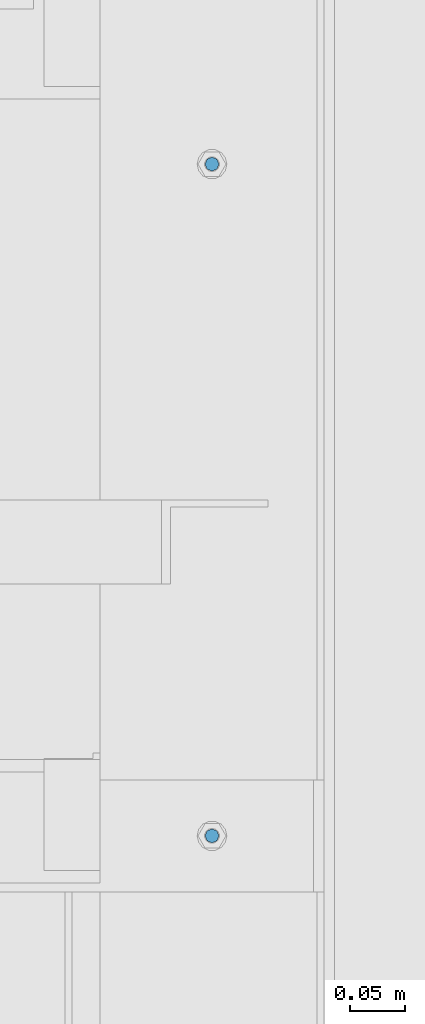
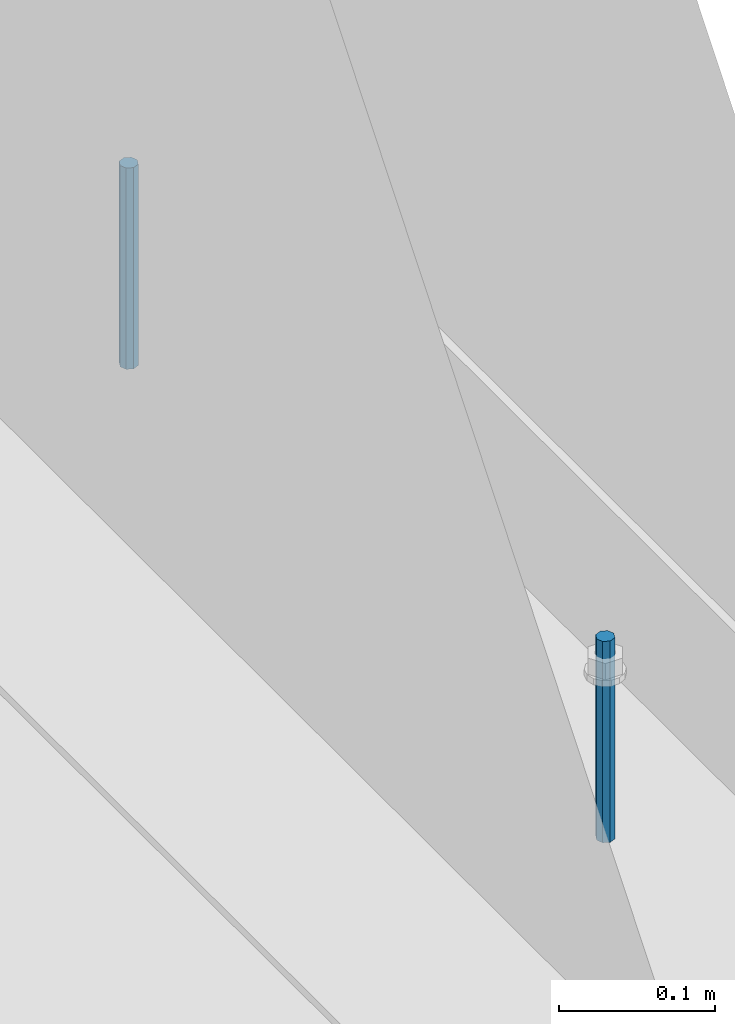
# One storey, part 441 of 1179: 2 columns, 1 element without a shape of its own.
"""IFC2X3 building model written with IfcOpenShell, lengths in millimetres."""

from ifc_helpers import new_model, si_unit, frame, origin_with_axes, place, context, subcontext, project, spatial, faceted_brep, material, type_object, element, aggregate, save


model = new_model("IFC2X3")

# Units and contexts
model_context = context("Model", 3, precision=1e-05, world=origin_with_axes())
body_context = subcontext(model_context, "Body", "Model", "MODEL_VIEW")
ifc_project = project(units=[si_unit("LENGTHUNIT", "METRE", prefix="MILLI"), si_unit("AREAUNIT", "SQUARE_METRE"), si_unit("VOLUMEUNIT", "CUBIC_METRE"), si_unit("MASSUNIT", "GRAM", prefix="KILO"), si_unit("TIMEUNIT", "SECOND"), si_unit("PLANEANGLEUNIT", "RADIAN"), si_unit("SOLIDANGLEUNIT", "STERADIAN"), si_unit("THERMODYNAMICTEMPERATUREUNIT", "DEGREE_CELSIUS"), si_unit("LUMINOUSINTENSITYUNIT", "LUMEN")], contexts=[model_context])

# Site, building, storey
site_placement = place(None, origin_with_axes())
site = spatial("IfcSite", under=ifc_project, at=site_placement, CompositionType="ELEMENT")
building_placement = place(site_placement, origin_with_axes())
building = spatial("IfcBuilding", under=site, at=building_placement, Name="Undefined", CompositionType="ELEMENT")
storey_placement = place(building_placement, origin_with_axes())
storey = spatial("IfcBuildingStorey", under=building, at=storey_placement, Name="Undefined", CompositionType="ELEMENT", Elevation=0.0)

# Assembly, columns
assembly_placement = place(storey_placement, origin_with_axes())
assembly = element("IfcElementAssembly", 1, at=assembly_placement, inside=storey, Name="BEAM", AssemblyPlace="NOTDEFINED", PredefinedType="RIGID_FRAME")
ifc_material = material(Name="STEEL/A307")
column_type = type_object("IfcColumnType", PredefinedType="NOTDEFINED")
column_1_placement = place(assembly_placement, frame((24638.0, 18402.3, 4108.45), z_axis=(0.0, 1.0, 0.0), x_axis=(0.0, 0.0, 1.0)))
column_1 = element("IfcColumn", 2, at=column_1_placement, type_object=column_type, material=ifc_material, Name="THREADED ROD", context=body_context, shape_type="Brep", body=[
    faceted_brep([(0.0, -6.34999999999854, 0.0), (0.0, -4.49012806053361, -4.49012806053452), (157.162499999999, -4.49012806053361, -4.49012806053361), (157.162499999999, -6.34999999999854, 0.0), (0.0, 0.0, -6.34999999999991), (157.162499999999, 0.0, -6.34999999999854), (0.0, 4.49012806053361, -4.49012806053452), (157.162499999999, 4.49012806053361, -4.49012806053361), (0.0, 6.34999999999854, 0.0), (157.162499999999, 6.34999999999854, 0.0), (0.0, 4.49012806053361, 4.49012806053452), (157.162499999999, 4.49012806053361, 4.49012806053361), (0.0, 0.0, 6.34999999999991), (157.162499999999, 0.0, 6.34999999999854), (0.0, -4.49012806053361, 4.49012806053452), (157.162499999999, -4.49012806053361, 4.49012806053361)], [[[0, 1, 2, 3]], [[1, 4, 5, 2]], [[4, 6, 7, 5]], [[6, 8, 9, 7]], [[8, 10, 11, 9]], [[10, 12, 13, 11]], [[12, 14, 15, 13]], [[14, 0, 3, 15]], [[5, 7, 9, 11, 13, 15, 3, 2]], [[14, 12, 10, 8, 6, 4, 1, 0]]]),
])
column_2_placement = place(assembly_placement, frame((24638.0, 17792.7, 4108.45), z_axis=(0.0, 1.0, 0.0), x_axis=(0.0, 0.0, 1.0)))
column_2 = element("IfcColumn", 3, at=column_2_placement, type_object=column_type, material=ifc_material, Name="THREADED ROD", context=body_context, shape_type="Brep", body=[
    faceted_brep([(0.0, -6.34999999999854, 0.0), (0.0, -4.49012806053361, -4.49012806053452), (157.162499999999, -4.49012806053361, -4.49012806053361), (157.162499999999, -6.34999999999854, 0.0), (0.0, 0.0, -6.34999999999991), (157.162499999999, 0.0, -6.34999999999854), (0.0, 4.49012806053361, -4.49012806053452), (157.162499999999, 4.49012806053361, -4.49012806053361), (0.0, 6.34999999999854, 0.0), (157.162499999999, 6.34999999999854, 0.0), (0.0, 4.49012806053361, 4.49012806053452), (157.162499999999, 4.49012806053361, 4.49012806053361), (0.0, 0.0, 6.34999999999991), (157.162499999999, 0.0, 6.34999999999854), (0.0, -4.49012806053361, 4.49012806053452), (157.162499999999, -4.49012806053361, 4.49012806053361)], [[[0, 1, 2, 3]], [[1, 4, 5, 2]], [[4, 6, 7, 5]], [[6, 8, 9, 7]], [[8, 10, 11, 9]], [[10, 12, 13, 11]], [[12, 14, 15, 13]], [[14, 0, 3, 15]], [[5, 7, 9, 11, 13, 15, 3, 2]], [[14, 12, 10, 8, 6, 4, 1, 0]]]),
])
aggregate(assembly, [column_1, column_2])

save(model, "model.ifc")
